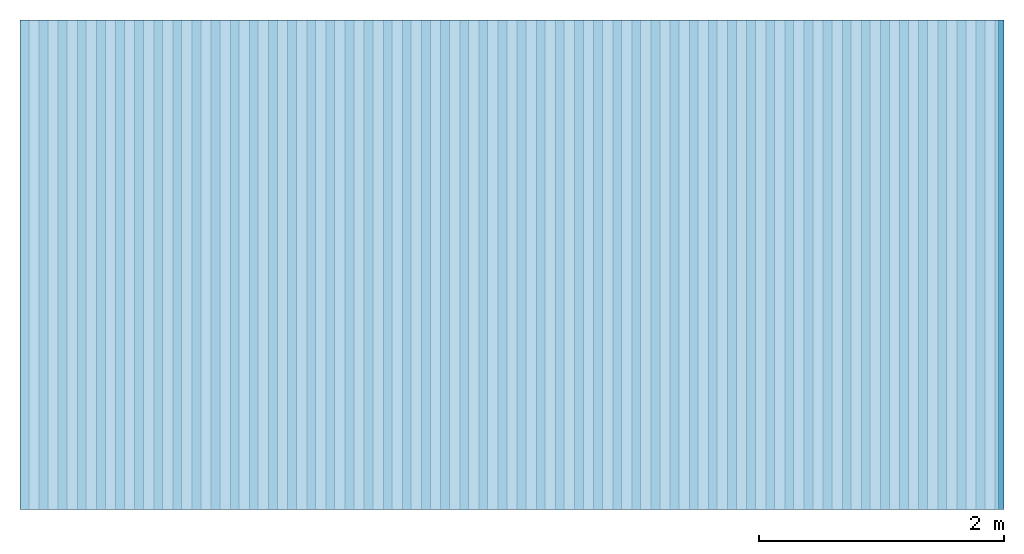
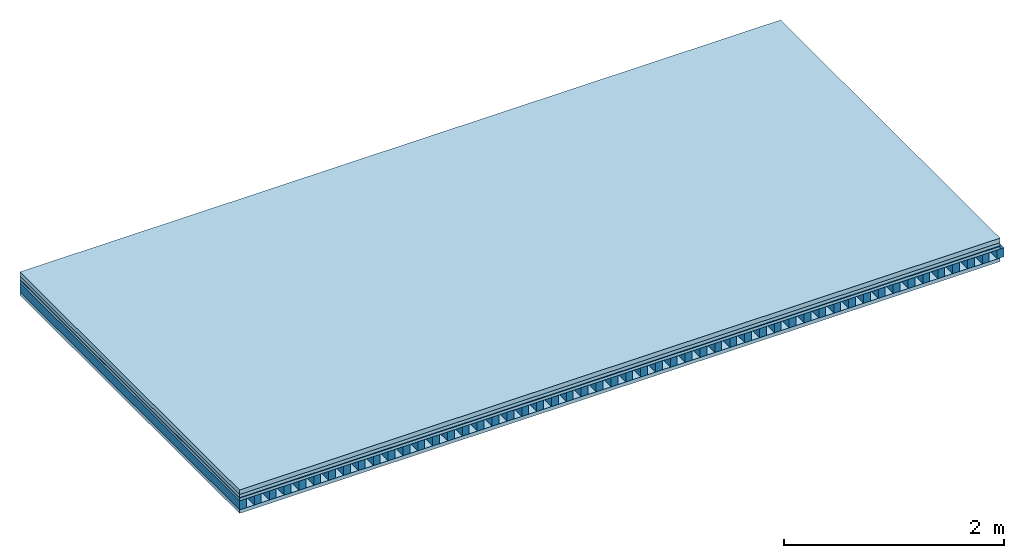
# One storey: 5 plates, 1 member, 1 element without a shape of its own.
"""IFC4 building model written with IfcOpenShell, lengths in metres."""

from ifc_helpers import new_model, si_unit, derived_unit, direction, frame, frame_2d, origin, origin_with_axes, place, context, project, spatial, rectangle, extrude, material, layer, layer_set, type_object, element, aggregate, save


model = new_model("IFC4")

# Units and contexts
plan_context = context("Plan", 3, precision=1e-05, world=origin(), true_north=direction((0.0, 1.0)))
model_context = context("Model", 3, precision=1e-05, world=origin(), true_north=direction((0.0, 1.0)))
ifc_project = project(units=[si_unit("LENGTHUNIT", "METRE"), derived_unit("SOUNDPRESSUREUNIT", [(si_unit("PRESSUREUNIT", "PASCAL", prefix="MICRO"), 0)]), si_unit("ENERGYUNIT", "JOULE", prefix="MEGA"), si_unit("MASSUNIT", "GRAM", prefix="KILO"), derived_unit("THERMALTRANSMITTANCEUNIT", [(si_unit("POWERUNIT", "WATT"), 1), (si_unit("AREAUNIT", "SQUARE_METRE"), -1), (si_unit("THERMODYNAMICTEMPERATUREUNIT", "KELVIN"), -1)]), derived_unit("AREADENSITYUNIT", [(si_unit("MASSUNIT", "GRAM", prefix="KILO"), 1), (si_unit("AREAUNIT", "SQUARE_METRE"), -1)]), derived_unit("USERDEFINED", [(si_unit("ENERGYUNIT", "JOULE", prefix="MEGA"), 1), (si_unit("AREAUNIT", "SQUARE_METRE"), -1)])], contexts=[plan_context, model_context])

# Site, building, storey
site = spatial("IfcSite", under=ifc_project)
building_placement = place(None, origin())
building = spatial("IfcBuilding", under=site, at=building_placement)
storey_placement = place(building_placement, origin())
storey = spatial("IfcBuildingStorey", under=building, at=storey_placement)

# Slab, member, plates
ifc_material_1 = material(Name="Cement screed", Category="04.006")
ifc_layer_1 = layer(ifc_material_1, 0.05, Name="On-material")
ifc_material_2 = material(Name="EP1, 35mm")
ifc_layer_2 = layer(ifc_material_2, 0.035, Name="Impact sound insulation")
ifc_material_3 = material(Name="Step 6mm", Category="10.009")
ifc_layer_3 = layer(ifc_material_3, 0.006, Name="Additional insulation")
ifc_material_4 = material()
ifc_layer_4 = layer(ifc_material_4, 0.03, Name="Sub-floor")
ifc_material_5 = material(Name="Rigid, of the art")
ifc_layer_5 = layer(ifc_material_5, 0.0, Name="Bond")
ifc_layer_6 = layer(None, 0.1, Name="Supporting structure")
ifc_layer_7 = layer(ifc_material_5, 0.0, Name="Bond")
ifc_material_6 = material(Name="panel on the underside HBF 40mm (20+20mm)", Category="07.001")
ifc_layer_8 = layer(ifc_material_6, 0.04, Name="Lower layer 1")
ifc_layer_set = layer_set([ifc_layer_1, ifc_layer_2, ifc_layer_3, ifc_layer_4, ifc_layer_5, ifc_layer_6, ifc_layer_7, ifc_layer_8])
slab_type = type_object("IfcSlabType", Name="A0089", PredefinedType="NOTDEFINED", material=ifc_layer_set)
slab_placement = place(None, frame((0.0, 0.0, 0.0), z_axis=(0.0, 0.0, -1.0), x_axis=(1.0, 0.0, 0.0)))
slab = element("IfcSlab", 1, at=slab_placement, inside=storey, type_object=slab_type, material=ifc_layer_set, Name="Slab #1")
ifc_material_7 = material(Name="Block Q4")
member_placement = place(slab_placement, origin())
member = element("IfcMember", 2, at=member_placement, material=ifc_material_7, Name="Supporting structure", context=plan_context, shape_type="SweptSolid", body=[
    extrude(rectangle(XDim=0.071666666666667, YDim=0.1, at=frame_2d((0.0358333333333335, 0.05), x_axis=(1.0, 0.0))), frame((0.0, 4.0, 0.121), z_axis=(0.0, -1.0, 0.0), x_axis=(1.0, 0.0, 0.0)), (0.0, 0.0, 1.0), 4.0),
    extrude(rectangle(XDim=0.071666666666667, YDim=0.1, at=frame_2d((0.0358333333333335, 0.05), x_axis=(1.0, 0.0))), frame((0.15625, 4.0, 0.121), z_axis=(0.0, -1.0, 0.0), x_axis=(1.0, 0.0, 0.0)), (0.0, 0.0, 1.0), 4.0),
    extrude(rectangle(XDim=0.071666666666667, YDim=0.1, at=frame_2d((0.0358333333333335, 0.05), x_axis=(1.0, 0.0))), frame((0.3125, 4.0, 0.121), z_axis=(0.0, -1.0, 0.0), x_axis=(1.0, 0.0, 0.0)), (0.0, 0.0, 1.0), 4.0),
    extrude(rectangle(XDim=0.071666666666667, YDim=0.1, at=frame_2d((0.0358333333333335, 0.05), x_axis=(1.0, 0.0))), frame((0.46875, 4.0, 0.121), z_axis=(0.0, -1.0, 0.0), x_axis=(1.0, 0.0, 0.0)), (0.0, 0.0, 1.0), 4.0),
    extrude(rectangle(XDim=0.071666666666667, YDim=0.1, at=frame_2d((0.0358333333333335, 0.05), x_axis=(1.0, 0.0))), frame((0.625, 4.0, 0.121), z_axis=(0.0, -1.0, 0.0), x_axis=(1.0, 0.0, 0.0)), (0.0, 0.0, 1.0), 4.0),
    extrude(rectangle(XDim=0.071666666666667, YDim=0.1, at=frame_2d((0.0358333333333335, 0.05), x_axis=(1.0, 0.0))), frame((0.78125, 4.0, 0.121), z_axis=(0.0, -1.0, 0.0), x_axis=(1.0, 0.0, 0.0)), (0.0, 0.0, 1.0), 4.0),
    extrude(rectangle(XDim=0.071666666666667, YDim=0.1, at=frame_2d((0.0358333333333335, 0.05), x_axis=(1.0, 0.0))), frame((0.9375, 4.0, 0.121), z_axis=(0.0, -1.0, 0.0), x_axis=(1.0, 0.0, 0.0)), (0.0, 0.0, 1.0), 4.0),
    extrude(rectangle(XDim=0.071666666666667, YDim=0.1, at=frame_2d((0.0358333333333335, 0.05), x_axis=(1.0, 0.0))), frame((1.09375, 4.0, 0.121), z_axis=(0.0, -1.0, 0.0), x_axis=(1.0, 0.0, 0.0)), (0.0, 0.0, 1.0), 4.0),
    extrude(rectangle(XDim=0.071666666666667, YDim=0.1, at=frame_2d((0.0358333333333335, 0.05), x_axis=(1.0, 0.0))), frame((1.25, 4.0, 0.121), z_axis=(0.0, -1.0, 0.0), x_axis=(1.0, 0.0, 0.0)), (0.0, 0.0, 1.0), 4.0),
    extrude(rectangle(XDim=0.071666666666667, YDim=0.1, at=frame_2d((0.0358333333333335, 0.05), x_axis=(1.0, 0.0))), frame((1.40625, 4.0, 0.121), z_axis=(0.0, -1.0, 0.0), x_axis=(1.0, 0.0, 0.0)), (0.0, 0.0, 1.0), 4.0),
    extrude(rectangle(XDim=0.071666666666667, YDim=0.1, at=frame_2d((0.0358333333333335, 0.05), x_axis=(1.0, 0.0))), frame((1.5625, 4.0, 0.121), z_axis=(0.0, -1.0, 0.0), x_axis=(1.0, 0.0, 0.0)), (0.0, 0.0, 1.0), 4.0),
    extrude(rectangle(XDim=0.071666666666667, YDim=0.1, at=frame_2d((0.0358333333333335, 0.05), x_axis=(1.0, 0.0))), frame((1.71875, 4.0, 0.121), z_axis=(0.0, -1.0, 0.0), x_axis=(1.0, 0.0, 0.0)), (0.0, 0.0, 1.0), 4.0),
    extrude(rectangle(XDim=0.071666666666667, YDim=0.1, at=frame_2d((0.0358333333333335, 0.05), x_axis=(1.0, 0.0))), frame((1.875, 4.0, 0.121), z_axis=(0.0, -1.0, 0.0), x_axis=(1.0, 0.0, 0.0)), (0.0, 0.0, 1.0), 4.0),
    extrude(rectangle(XDim=0.071666666666667, YDim=0.1, at=frame_2d((0.0358333333333335, 0.05), x_axis=(1.0, 0.0))), frame((2.03125, 4.0, 0.121), z_axis=(0.0, -1.0, 0.0), x_axis=(1.0, 0.0, 0.0)), (0.0, 0.0, 1.0), 4.0),
    extrude(rectangle(XDim=0.071666666666667, YDim=0.1, at=frame_2d((0.0358333333333335, 0.05), x_axis=(1.0, 0.0))), frame((2.1875, 4.0, 0.121), z_axis=(0.0, -1.0, 0.0), x_axis=(1.0, 0.0, 0.0)), (0.0, 0.0, 1.0), 4.0),
    extrude(rectangle(XDim=0.071666666666667, YDim=0.1, at=frame_2d((0.0358333333333335, 0.05), x_axis=(1.0, 0.0))), frame((2.34375, 4.0, 0.121), z_axis=(0.0, -1.0, 0.0), x_axis=(1.0, 0.0, 0.0)), (0.0, 0.0, 1.0), 4.0),
    extrude(rectangle(XDim=0.071666666666667, YDim=0.1, at=frame_2d((0.0358333333333335, 0.05), x_axis=(1.0, 0.0))), frame((2.5, 4.0, 0.121), z_axis=(0.0, -1.0, 0.0), x_axis=(1.0, 0.0, 0.0)), (0.0, 0.0, 1.0), 4.0),
    extrude(rectangle(XDim=0.071666666666667, YDim=0.1, at=frame_2d((0.0358333333333335, 0.05), x_axis=(1.0, 0.0))), frame((2.65625, 4.0, 0.121), z_axis=(0.0, -1.0, 0.0), x_axis=(1.0, 0.0, 0.0)), (0.0, 0.0, 1.0), 4.0),
    extrude(rectangle(XDim=0.071666666666667, YDim=0.1, at=frame_2d((0.0358333333333335, 0.05), x_axis=(1.0, 0.0))), frame((2.8125, 4.0, 0.121), z_axis=(0.0, -1.0, 0.0), x_axis=(1.0, 0.0, 0.0)), (0.0, 0.0, 1.0), 4.0),
    extrude(rectangle(XDim=0.071666666666667, YDim=0.1, at=frame_2d((0.0358333333333335, 0.05), x_axis=(1.0, 0.0))), frame((2.96875, 4.0, 0.121), z_axis=(0.0, -1.0, 0.0), x_axis=(1.0, 0.0, 0.0)), (0.0, 0.0, 1.0), 4.0),
    extrude(rectangle(XDim=0.071666666666667, YDim=0.1, at=frame_2d((0.0358333333333335, 0.05), x_axis=(1.0, 0.0))), frame((3.125, 4.0, 0.121), z_axis=(0.0, -1.0, 0.0), x_axis=(1.0, 0.0, 0.0)), (0.0, 0.0, 1.0), 4.0),
    extrude(rectangle(XDim=0.071666666666667, YDim=0.1, at=frame_2d((0.0358333333333335, 0.05), x_axis=(1.0, 0.0))), frame((3.28125, 4.0, 0.121), z_axis=(0.0, -1.0, 0.0), x_axis=(1.0, 0.0, 0.0)), (0.0, 0.0, 1.0), 4.0),
    extrude(rectangle(XDim=0.071666666666667, YDim=0.1, at=frame_2d((0.0358333333333335, 0.05), x_axis=(1.0, 0.0))), frame((3.4375, 4.0, 0.121), z_axis=(0.0, -1.0, 0.0), x_axis=(1.0, 0.0, 0.0)), (0.0, 0.0, 1.0), 4.0),
    extrude(rectangle(XDim=0.071666666666667, YDim=0.1, at=frame_2d((0.0358333333333335, 0.05), x_axis=(1.0, 0.0))), frame((3.59375, 4.0, 0.121), z_axis=(0.0, -1.0, 0.0), x_axis=(1.0, 0.0, 0.0)), (0.0, 0.0, 1.0), 4.0),
    extrude(rectangle(XDim=0.071666666666667, YDim=0.1, at=frame_2d((0.0358333333333335, 0.05), x_axis=(1.0, 0.0))), frame((3.75, 4.0, 0.121), z_axis=(0.0, -1.0, 0.0), x_axis=(1.0, 0.0, 0.0)), (0.0, 0.0, 1.0), 4.0),
    extrude(rectangle(XDim=0.071666666666667, YDim=0.1, at=frame_2d((0.0358333333333335, 0.05), x_axis=(1.0, 0.0))), frame((3.90625, 4.0, 0.121), z_axis=(0.0, -1.0, 0.0), x_axis=(1.0, 0.0, 0.0)), (0.0, 0.0, 1.0), 4.0),
    extrude(rectangle(XDim=0.071666666666667, YDim=0.1, at=frame_2d((0.0358333333333335, 0.05), x_axis=(1.0, 0.0))), frame((4.0625, 4.0, 0.121), z_axis=(0.0, -1.0, 0.0), x_axis=(1.0, 0.0, 0.0)), (0.0, 0.0, 1.0), 4.0),
    extrude(rectangle(XDim=0.071666666666667, YDim=0.1, at=frame_2d((0.0358333333333335, 0.05), x_axis=(1.0, 0.0))), frame((4.21875, 4.0, 0.121), z_axis=(0.0, -1.0, 0.0), x_axis=(1.0, 0.0, 0.0)), (0.0, 0.0, 1.0), 4.0),
    extrude(rectangle(XDim=0.071666666666667, YDim=0.1, at=frame_2d((0.0358333333333335, 0.05), x_axis=(1.0, 0.0))), frame((4.375, 4.0, 0.121), z_axis=(0.0, -1.0, 0.0), x_axis=(1.0, 0.0, 0.0)), (0.0, 0.0, 1.0), 4.0),
    extrude(rectangle(XDim=0.071666666666667, YDim=0.1, at=frame_2d((0.0358333333333335, 0.05), x_axis=(1.0, 0.0))), frame((4.53125, 4.0, 0.121), z_axis=(0.0, -1.0, 0.0), x_axis=(1.0, 0.0, 0.0)), (0.0, 0.0, 1.0), 4.0),
    extrude(rectangle(XDim=0.071666666666667, YDim=0.1, at=frame_2d((0.0358333333333335, 0.05), x_axis=(1.0, 0.0))), frame((4.6875, 4.0, 0.121), z_axis=(0.0, -1.0, 0.0), x_axis=(1.0, 0.0, 0.0)), (0.0, 0.0, 1.0), 4.0),
    extrude(rectangle(XDim=0.071666666666667, YDim=0.1, at=frame_2d((0.0358333333333335, 0.05), x_axis=(1.0, 0.0))), frame((4.84375, 4.0, 0.121), z_axis=(0.0, -1.0, 0.0), x_axis=(1.0, 0.0, 0.0)), (0.0, 0.0, 1.0), 4.0),
    extrude(rectangle(XDim=0.071666666666667, YDim=0.1, at=frame_2d((0.0358333333333335, 0.05), x_axis=(1.0, 0.0))), frame((5.0, 4.0, 0.121), z_axis=(0.0, -1.0, 0.0), x_axis=(1.0, 0.0, 0.0)), (0.0, 0.0, 1.0), 4.0),
    extrude(rectangle(XDim=0.071666666666667, YDim=0.1, at=frame_2d((0.0358333333333335, 0.05), x_axis=(1.0, 0.0))), frame((5.15625, 4.0, 0.121), z_axis=(0.0, -1.0, 0.0), x_axis=(1.0, 0.0, 0.0)), (0.0, 0.0, 1.0), 4.0),
    extrude(rectangle(XDim=0.071666666666667, YDim=0.1, at=frame_2d((0.0358333333333335, 0.05), x_axis=(1.0, 0.0))), frame((5.3125, 4.0, 0.121), z_axis=(0.0, -1.0, 0.0), x_axis=(1.0, 0.0, 0.0)), (0.0, 0.0, 1.0), 4.0),
    extrude(rectangle(XDim=0.071666666666667, YDim=0.1, at=frame_2d((0.0358333333333335, 0.05), x_axis=(1.0, 0.0))), frame((5.46875, 4.0, 0.121), z_axis=(0.0, -1.0, 0.0), x_axis=(1.0, 0.0, 0.0)), (0.0, 0.0, 1.0), 4.0),
    extrude(rectangle(XDim=0.071666666666667, YDim=0.1, at=frame_2d((0.0358333333333335, 0.05), x_axis=(1.0, 0.0))), frame((5.625, 4.0, 0.121), z_axis=(0.0, -1.0, 0.0), x_axis=(1.0, 0.0, 0.0)), (0.0, 0.0, 1.0), 4.0),
    extrude(rectangle(XDim=0.071666666666667, YDim=0.1, at=frame_2d((0.0358333333333335, 0.05), x_axis=(1.0, 0.0))), frame((5.78125, 4.0, 0.121), z_axis=(0.0, -1.0, 0.0), x_axis=(1.0, 0.0, 0.0)), (0.0, 0.0, 1.0), 4.0),
    extrude(rectangle(XDim=0.071666666666667, YDim=0.1, at=frame_2d((0.0358333333333335, 0.05), x_axis=(1.0, 0.0))), frame((5.9375, 4.0, 0.121), z_axis=(0.0, -1.0, 0.0), x_axis=(1.0, 0.0, 0.0)), (0.0, 0.0, 1.0), 4.0),
    extrude(rectangle(XDim=0.071666666666667, YDim=0.1, at=frame_2d((0.0358333333333335, 0.05), x_axis=(1.0, 0.0))), frame((6.09375, 4.0, 0.121), z_axis=(0.0, -1.0, 0.0), x_axis=(1.0, 0.0, 0.0)), (0.0, 0.0, 1.0), 4.0),
    extrude(rectangle(XDim=0.071666666666667, YDim=0.1, at=frame_2d((0.0358333333333335, 0.05), x_axis=(1.0, 0.0))), frame((6.25, 4.0, 0.121), z_axis=(0.0, -1.0, 0.0), x_axis=(1.0, 0.0, 0.0)), (0.0, 0.0, 1.0), 4.0),
    extrude(rectangle(XDim=0.071666666666667, YDim=0.1, at=frame_2d((0.0358333333333335, 0.05), x_axis=(1.0, 0.0))), frame((6.40625, 4.0, 0.121), z_axis=(0.0, -1.0, 0.0), x_axis=(1.0, 0.0, 0.0)), (0.0, 0.0, 1.0), 4.0),
    extrude(rectangle(XDim=0.071666666666667, YDim=0.1, at=frame_2d((0.0358333333333335, 0.05), x_axis=(1.0, 0.0))), frame((6.5625, 4.0, 0.121), z_axis=(0.0, -1.0, 0.0), x_axis=(1.0, 0.0, 0.0)), (0.0, 0.0, 1.0), 4.0),
    extrude(rectangle(XDim=0.071666666666667, YDim=0.1, at=frame_2d((0.0358333333333335, 0.05), x_axis=(1.0, 0.0))), frame((6.71875, 4.0, 0.121), z_axis=(0.0, -1.0, 0.0), x_axis=(1.0, 0.0, 0.0)), (0.0, 0.0, 1.0), 4.0),
    extrude(rectangle(XDim=0.071666666666667, YDim=0.1, at=frame_2d((0.0358333333333335, 0.05), x_axis=(1.0, 0.0))), frame((6.875, 4.0, 0.121), z_axis=(0.0, -1.0, 0.0), x_axis=(1.0, 0.0, 0.0)), (0.0, 0.0, 1.0), 4.0),
    extrude(rectangle(XDim=0.071666666666667, YDim=0.1, at=frame_2d((0.0358333333333335, 0.05), x_axis=(1.0, 0.0))), frame((7.03125, 4.0, 0.121), z_axis=(0.0, -1.0, 0.0), x_axis=(1.0, 0.0, 0.0)), (0.0, 0.0, 1.0), 4.0),
    extrude(rectangle(XDim=0.071666666666667, YDim=0.1, at=frame_2d((0.0358333333333335, 0.05), x_axis=(1.0, 0.0))), frame((7.1875, 4.0, 0.121), z_axis=(0.0, -1.0, 0.0), x_axis=(1.0, 0.0, 0.0)), (0.0, 0.0, 1.0), 4.0),
    extrude(rectangle(XDim=0.071666666666667, YDim=0.1, at=frame_2d((0.0358333333333335, 0.05), x_axis=(1.0, 0.0))), frame((7.34375, 4.0, 0.121), z_axis=(0.0, -1.0, 0.0), x_axis=(1.0, 0.0, 0.0)), (0.0, 0.0, 1.0), 4.0),
    extrude(rectangle(XDim=0.071666666666667, YDim=0.1, at=frame_2d((0.0358333333333335, 0.05), x_axis=(1.0, 0.0))), frame((7.5, 4.0, 0.121), z_axis=(0.0, -1.0, 0.0), x_axis=(1.0, 0.0, 0.0)), (0.0, 0.0, 1.0), 4.0),
    extrude(rectangle(XDim=0.071666666666667, YDim=0.1, at=frame_2d((0.0358333333333335, 0.05), x_axis=(1.0, 0.0))), frame((7.65625, 4.0, 0.121), z_axis=(0.0, -1.0, 0.0), x_axis=(1.0, 0.0, 0.0)), (0.0, 0.0, 1.0), 4.0),
    extrude(rectangle(XDim=0.071666666666667, YDim=0.1, at=frame_2d((0.0358333333333335, 0.05), x_axis=(1.0, 0.0))), frame((7.8125, 4.0, 0.121), z_axis=(0.0, -1.0, 0.0), x_axis=(1.0, 0.0, 0.0)), (0.0, 0.0, 1.0), 4.0),
    extrude(rectangle(XDim=0.071666666666667, YDim=0.1, at=frame_2d((0.0358333333333335, 0.05), x_axis=(1.0, 0.0))), frame((7.96875, 4.0, 0.121), z_axis=(0.0, -1.0, 0.0), x_axis=(1.0, 0.0, 0.0)), (0.0, 0.0, 1.0), 4.0),
])
plate_1_placement = place(slab_placement, origin())
plate_1 = element("IfcPlate", 3, at=plate_1_placement, material=ifc_material_1, Name="On-material", context=plan_context, shape_type="SweptSolid", body=[
    extrude(rectangle(XDim=8.0, YDim=4.0, at=frame_2d((4.0, 2.0), x_axis=(1.0, 0.0))), origin_with_axes(), (0.0, 0.0, 1.0), 0.05),
])
plate_2_placement = place(slab_placement, origin())
plate_2 = element("IfcPlate", 4, at=plate_2_placement, material=ifc_material_2, Name="Impact sound insulation", context=plan_context, shape_type="SweptSolid", body=[
    extrude(rectangle(XDim=8.0, YDim=4.0, at=frame_2d((4.0, 2.0), x_axis=(1.0, 0.0))), frame((0.0, 0.0, 0.05), z_axis=(0.0, 0.0, 1.0), x_axis=(1.0, 0.0, 0.0)), (0.0, 0.0, 1.0), 0.035),
])
plate_3_placement = place(slab_placement, origin())
plate_3 = element("IfcPlate", 5, at=plate_3_placement, material=ifc_material_3, Name="Additional insulation", context=plan_context, shape_type="SweptSolid", body=[
    extrude(rectangle(XDim=8.0, YDim=4.0, at=frame_2d((4.0, 2.0), x_axis=(1.0, 0.0))), frame((0.0, 0.0, 0.085), z_axis=(0.0, 0.0, 1.0), x_axis=(1.0, 0.0, 0.0)), (0.0, 0.0, 1.0), 0.006),
])
plate_4_placement = place(slab_placement, origin())
plate_4 = element("IfcPlate", 6, at=plate_4_placement, material=ifc_material_4, Name="Sub-floor", context=plan_context, shape_type="SweptSolid", body=[
    extrude(rectangle(XDim=8.0, YDim=4.0, at=frame_2d((4.0, 2.0), x_axis=(1.0, 0.0))), frame((0.0, 0.0, 0.091), z_axis=(0.0, 0.0, 1.0), x_axis=(1.0, 0.0, 0.0)), (0.0, 0.0, 1.0), 0.03),
])
plate_5_placement = place(slab_placement, origin())
plate_5 = element("IfcPlate", 7, at=plate_5_placement, material=ifc_material_6, Name="Lower layer 1", context=plan_context, shape_type="SweptSolid", body=[
    extrude(rectangle(XDim=8.0, YDim=4.0, at=frame_2d((4.0, 2.0), x_axis=(1.0, 0.0))), frame((0.0, 0.0, 0.221), z_axis=(0.0, 0.0, 1.0), x_axis=(1.0, 0.0, 0.0)), (0.0, 0.0, 1.0), 0.04),
])
aggregate(slab, [plate_1, plate_2, plate_3, plate_4, member, plate_5])

save(model, "model.ifc")
